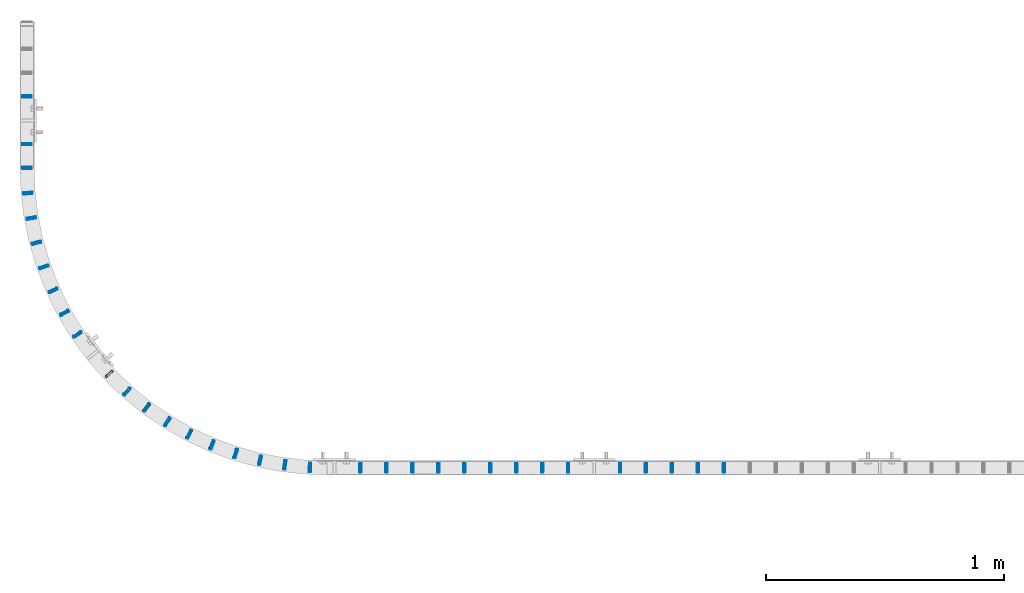
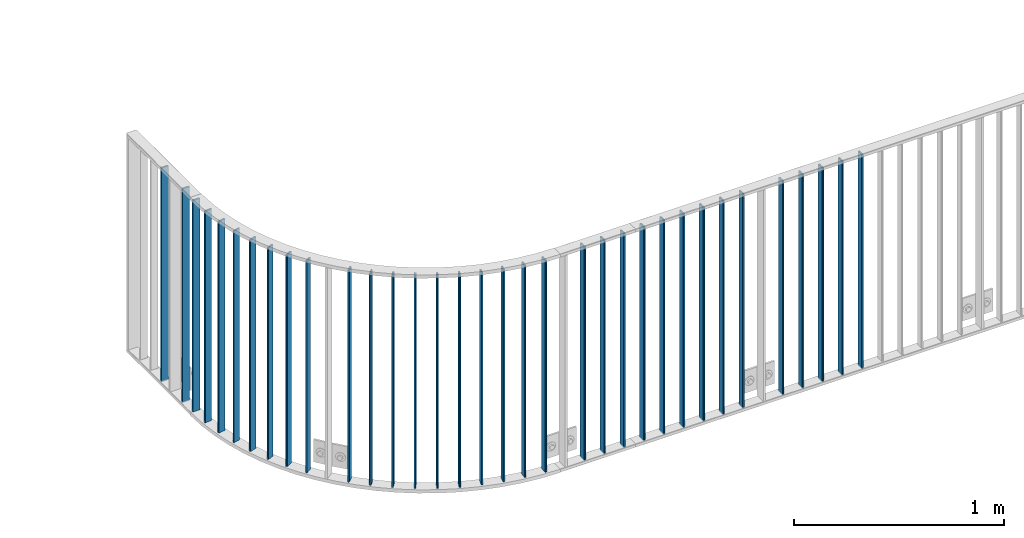
# One storey, part 1 of 156: 34 beams, 2 elements without a shape of their own.
"""IFC2X3 building model written with IfcOpenShell, lengths in millimetres."""

from ifc_helpers import new_model, si_unit, frame, origin_with_axes, origin_2d_with_axis, place, context, subcontext, project, spatial, hollow_rectangle, extrude, clip, halfspace, material, type_object, element, aggregate, save


model = new_model("IFC2X3")

# Units and contexts
model_context = context("Model", 3, precision=1e-05, world=origin_with_axes())
body_context = subcontext(model_context, "Body", "Model", "MODEL_VIEW")
ifc_project = project(units=[si_unit("LENGTHUNIT", "METRE", prefix="MILLI"), si_unit("AREAUNIT", "SQUARE_METRE"), si_unit("VOLUMEUNIT", "CUBIC_METRE"), si_unit("MASSUNIT", "GRAM", prefix="KILO"), si_unit("TIMEUNIT", "SECOND"), si_unit("PLANEANGLEUNIT", "RADIAN"), si_unit("SOLIDANGLEUNIT", "STERADIAN"), si_unit("THERMODYNAMICTEMPERATUREUNIT", "DEGREE_CELSIUS"), si_unit("LUMINOUSINTENSITYUNIT", "LUMEN")], contexts=[model_context])

# Site, building, storey
site_placement = place(None, origin_with_axes())
site = spatial("IfcSite", under=ifc_project, at=site_placement, CompositionType="ELEMENT")
building_placement = place(site_placement, origin_with_axes())
building = spatial("IfcBuilding", under=site, at=building_placement, Name="Undefined", CompositionType="ELEMENT")
storey_placement = place(building_placement, origin_with_axes())
storey = spatial("IfcBuildingStorey", under=building, at=storey_placement, Name="Undefined", CompositionType="ELEMENT", Elevation=0.0)

# Assembly, beams
assembly_1_placement = place(storey_placement, origin_with_axes())
assembly_1 = element("IfcElementAssembly", 1, at=assembly_1_placement, inside=storey, AssemblyPlace="NOTDEFINED", PredefinedType="RIGID_FRAME")
ifc_material = material(Name="STEEL/S235JR")
beam_type = type_object("IfcBeamType", Name="K40/10/1.5", PredefinedType="NOTDEFINED")
beam_1_placement = place(assembly_1_placement, frame((9618.18999999898, 10879.9998093347, 3980.00000000003), z_axis=(0.0, 1.0, 0.0), x_axis=(0.0, 0.0, -1.0)))
beam_1 = element("IfcBeam", 2, at=beam_1_placement, type_object=beam_type, material=ifc_material, ObjectType="K40/10/1.5", context=body_context, shape_type="Clipping", body=[
    clip(clip(extrude(hollow_rectangle(XDim=10.0, YDim=40.0, WallThickness=1.5, InnerFilletRadius=1.5, OuterFilletRadius=3.0, at=origin_2d_with_axis()), frame((1237.00000000003, 0.0, 0.0), z_axis=(-1.0, 0.0, 0.0), x_axis=(0.0, -1.0, 0.0)), (0.0, 0.0, 1.0), 1244.0), halfspace(frame((1237.00000000003, -56.3749450640607, -3.21677039569113), z_axis=(1.0, 0.0, 0.0), x_axis=(0.0, -0.0578016017852366, -0.998328089773628)), False)), halfspace(frame((-6.99999999997408, 56.3749450528248, -3.21677038838243), z_axis=(-1.0, 0.0, 0.0), x_axis=(0.0, 0.0578016019523036, -0.998328089763955)), False)),
])
beam_2_placement = place(assembly_1_placement, frame((8216.99947364132, 12239.9989152168, 3980.00000000003), z_axis=(1.0, 0.0, 0.0), x_axis=(0.0, 0.0, -1.0)))
beam_2 = element("IfcBeam", 3, at=beam_2_placement, type_object=beam_type, material=ifc_material, ObjectType="K40/10/1.5", context=body_context, shape_type="Clipping", body=[
    clip(clip(extrude(hollow_rectangle(XDim=10.0, YDim=40.0, WallThickness=1.5, InnerFilletRadius=1.5, OuterFilletRadius=3.0, at=origin_2d_with_axis()), frame((1237.00000000003, 0.0, 0.0), z_axis=(-1.0, 0.0, 0.0), x_axis=(0.0, -1.0, 0.0)), (0.0, 0.0, 1.0), 1244.0), halfspace(frame((1237.00000000003, -56.3749450640607, -3.21677039569113), z_axis=(1.0, 0.0, 0.0), x_axis=(0.0, -0.0578016017852366, -0.998328089773628)), False)), halfspace(frame((-6.99999999997408, 56.3749450528248, -3.21677038838243), z_axis=(-1.0, 0.0, 0.0), x_axis=(0.0, 0.0578016019523036, -0.998328089763955)), False)),
])
beam_3_placement = place(assembly_1_placement, frame((8216.99947364132, 12439.9989152168, 3980.00000000003), z_axis=(1.0, 0.0, 0.0), x_axis=(0.0, 0.0, -1.0)))
beam_3 = element("IfcBeam", 4, at=beam_3_placement, type_object=beam_type, material=ifc_material, ObjectType="K40/10/1.5", context=body_context, shape_type="Clipping", body=[
    clip(clip(extrude(hollow_rectangle(XDim=10.0, YDim=40.0, WallThickness=1.5, InnerFilletRadius=1.5, OuterFilletRadius=3.0, at=origin_2d_with_axis()), frame((1237.00000000003, 0.0, 0.0), z_axis=(-1.0, 0.0, 0.0), x_axis=(0.0, -1.0, 0.0)), (0.0, 0.0, 1.0), 1244.0), halfspace(frame((1237.00000000003, -56.3749450640607, -3.21677039569113), z_axis=(1.0, 0.0, 0.0), x_axis=(0.0, -0.0578016017852366, -0.998328089773628)), False)), halfspace(frame((-6.99999999997408, 56.3749450528248, -3.21677038838243), z_axis=(-1.0, 0.0, 0.0), x_axis=(0.0, 0.0578016019523036, -0.998328089763955)), False)),
])
beam_4_placement = place(assembly_1_placement, frame((9405.79598262836, 10882.0035335241, 3980.00000000003), z_axis=(0.0565185340076896, 0.998401550135827, 0.0), x_axis=(0.0, 0.0, -1.0)))
beam_4 = element("IfcBeam", 5, at=beam_4_placement, type_object=beam_type, material=ifc_material, ObjectType="K40/10/1.5", context=body_context, shape_type="SweptSolid", body=[
    extrude(hollow_rectangle(XDim=10.0, YDim=40.0, WallThickness=1.5, InnerFilletRadius=1.5, OuterFilletRadius=3.0, at=origin_2d_with_axis()), frame((1230.0, 0.0, 0.0), z_axis=(-1.0, 0.0, 0.0), x_axis=(0.0, -1.0, 0.0)), (0.0, 0.0, 1.0), 1230.0),
])
beam_5_placement = place(assembly_1_placement, frame((9300.34381627942, 10892.4361317088, 3980.00000000003), z_axis=(0.1402100310039, 0.990121784027543, 0.0), x_axis=(0.0, 0.0, -1.0)))
beam_5 = element("IfcBeam", 6, at=beam_5_placement, type_object=beam_type, material=ifc_material, ObjectType="K40/10/1.5", context=body_context, shape_type="SweptSolid", body=[
    extrude(hollow_rectangle(XDim=10.0, YDim=40.0, WallThickness=1.5, InnerFilletRadius=1.5, OuterFilletRadius=3.0, at=origin_2d_with_axis()), frame((1230.0, 0.0, 0.0), z_axis=(-1.0, 0.0, 0.0), x_axis=(0.0, -1.0, 0.0)), (0.0, 0.0, 1.0), 1230.0),
])
beam_6_placement = place(assembly_1_placement, frame((9196.14117823786, 10911.6925259129, 3980.00000000003), z_axis=(0.222909846934246, 0.974839063712442, 0.0), x_axis=(0.0, 0.0, -1.0)))
beam_6 = element("IfcBeam", 7, at=beam_6_placement, type_object=beam_type, material=ifc_material, ObjectType="K40/10/1.5", context=body_context, shape_type="SweptSolid", body=[
    extrude(hollow_rectangle(XDim=10.0, YDim=40.0, WallThickness=1.5, InnerFilletRadius=1.5, OuterFilletRadius=3.0, at=origin_2d_with_axis()), frame((1230.0, 0.0, 0.0), z_axis=(-1.0, 0.0, 0.0), x_axis=(0.0, -1.0, 0.0)), (0.0, 0.0, 1.0), 1230.0),
])
beam_7_placement = place(assembly_1_placement, frame((9093.92507511803, 10939.6365191058, 3980.00000000003), z_axis=(0.304033061066562, 0.952661481208565, 0.0), x_axis=(0.0, 0.0, -1.0)))
beam_7 = element("IfcBeam", 8, at=beam_7_placement, type_object=beam_type, material=ifc_material, ObjectType="K40/10/1.5", context=body_context, shape_type="SweptSolid", body=[
    extrude(hollow_rectangle(XDim=10.0, YDim=40.0, WallThickness=1.5, InnerFilletRadius=1.5, OuterFilletRadius=3.0, at=origin_2d_with_axis()), frame((1230.0, 0.0, 0.0), z_axis=(-1.0, 0.0, 0.0), x_axis=(0.0, -1.0, 0.0)), (0.0, 0.0, 1.0), 1230.0),
])
beam_8_placement = place(assembly_1_placement, frame((8994.41846312824, 10976.0704684235, 3980.00000000003), z_axis=(0.383005903803094, 0.923745894525099, 0.0), x_axis=(0.0, 0.0, -1.0)))
beam_8 = element("IfcBeam", 9, at=beam_8_placement, type_object=beam_type, material=ifc_material, ObjectType="K40/10/1.5", context=body_context, shape_type="SweptSolid", body=[
    extrude(hollow_rectangle(XDim=10.0, YDim=40.0, WallThickness=1.5, InnerFilletRadius=1.5, OuterFilletRadius=3.0, at=origin_2d_with_axis()), frame((1230.0, 0.0, 0.0), z_axis=(-1.0, 0.0, 0.0), x_axis=(0.0, -1.0, 0.0)), (0.0, 0.0, 1.0), 1230.0),
])
beam_9_placement = place(assembly_1_placement, frame((8898.32513473082, 11020.7366830613, 3980.00000000003), z_axis=(0.459269815036958, 0.888296818071481, 0.0), x_axis=(0.0, 0.0, -1.0)))
beam_9 = element("IfcBeam", 10, at=beam_9_placement, type_object=beam_type, material=ifc_material, ObjectType="K40/10/1.5", context=body_context, shape_type="SweptSolid", body=[
    extrude(hollow_rectangle(XDim=10.0, YDim=40.0, WallThickness=1.5, InnerFilletRadius=1.5, OuterFilletRadius=3.0, at=origin_2d_with_axis()), frame((1230.0, 0.0, 0.0), z_axis=(-1.0, 0.0, 0.0), x_axis=(0.0, -1.0, 0.0)), (0.0, 0.0, 1.0), 1230.0),
])
beam_10_placement = place(assembly_1_placement, frame((8806.32474084398, 11073.3192468752, 3980.00000000003), z_axis=(0.532285391863539, 0.846564977782969, 0.0), x_axis=(0.0, 0.0, -1.0)))
beam_10 = element("IfcBeam", 11, at=beam_10_placement, type_object=beam_type, material=ifc_material, ObjectType="K40/10/1.5", context=body_context, shape_type="SweptSolid", body=[
    extrude(hollow_rectangle(XDim=10.0, YDim=40.0, WallThickness=1.5, InnerFilletRadius=1.5, OuterFilletRadius=3.0, at=origin_2d_with_axis()), frame((1230.0, 0.0, 0.0), z_axis=(-1.0, 0.0, 0.0), x_axis=(0.0, -1.0, 0.0)), (0.0, 0.0, 1.0), 1230.0),
])
beam_11_placement = place(assembly_1_placement, frame((8719.06798379248, 11133.4462527995, 3980.00000000003), z_axis=(0.601536210260794, 0.798845534346335, 0.0), x_axis=(0.0, 0.0, -1.0)))
beam_11 = element("IfcBeam", 12, at=beam_11_placement, type_object=beam_type, material=ifc_material, ObjectType="K40/10/1.5", context=body_context, shape_type="SweptSolid", body=[
    extrude(hollow_rectangle(XDim=10.0, YDim=40.0, WallThickness=1.5, InnerFilletRadius=1.5, OuterFilletRadius=3.0, at=origin_2d_with_axis()), frame((1230.0, 0.0, 0.0), z_axis=(-1.0, 0.0, 0.0), x_axis=(0.0, -1.0, 0.0)), (0.0, 0.0, 1.0), 1230.0),
])
beam_12_placement = place(assembly_1_placement, frame((8637.17201500647, 11200.6924332796, 3980.00000000003), z_axis=(0.666532469953243, 0.745475999947704, 0.0), x_axis=(0.0, 0.0, -1.0)))
beam_12 = element("IfcBeam", 13, at=beam_12_placement, type_object=beam_type, material=ifc_material, ObjectType="K40/10/1.5", context=body_context, shape_type="SweptSolid", body=[
    extrude(hollow_rectangle(XDim=10.0, YDim=40.0, WallThickness=1.5, InnerFilletRadius=1.5, OuterFilletRadius=3.0, at=origin_2d_with_axis()), frame((1230.0, 0.0, 0.0), z_axis=(-1.0, 0.0, 0.0), x_axis=(0.0, -1.0, 0.0)), (0.0, 0.0, 1.0), 1230.0),
])
beam_13_placement = place(assembly_1_placement, frame((8561.21607001991, 11274.5821681131, 3980.00000000003), z_axis=(0.726814465029779, 0.686833847028142, 0.0), x_axis=(0.0, 0.0, -1.0)))
beam_13 = element("IfcBeam", 14, at=beam_13_placement, type_object=beam_type, material=ifc_material, ObjectType="K40/10/1.5", context=body_context, shape_type="SweptSolid", body=[
    extrude(hollow_rectangle(XDim=10.0, YDim=40.0, WallThickness=1.5, InnerFilletRadius=1.5, OuterFilletRadius=3.0, at=origin_2d_with_axis()), frame((1230.0, 0.0, 0.0), z_axis=(-1.0, 0.0, 0.0), x_axis=(0.0, -1.0, 0.0)), (0.0, 0.0, 1.0), 1230.0),
])
beam_14_placement = place(assembly_1_placement, frame((8429.22733027256, 11440.1585729931, 3980.00000000003), z_axis=(0.831566564833267, 0.555425105888634, 0.0), x_axis=(0.0, 0.0, -1.0)))
beam_14 = element("IfcBeam", 15, at=beam_14_placement, type_object=beam_type, material=ifc_material, ObjectType="K40/10/1.5", context=body_context, shape_type="SweptSolid", body=[
    extrude(hollow_rectangle(XDim=10.0, YDim=40.0, WallThickness=1.5, InnerFilletRadius=1.5, OuterFilletRadius=3.0, at=origin_2d_with_axis()), frame((1230.0, 0.0, 0.0), z_axis=(-1.0, 0.0, 0.0), x_axis=(0.0, -1.0, 0.0)), (0.0, 0.0, 1.0), 1230.0),
])
beam_15_placement = place(assembly_1_placement, frame((8374.12806825185, 11530.6741507538, 3980.00000000003), z_axis=(0.875295776043121, 0.483587949023826, 0.0), x_axis=(0.0, 0.0, -1.0)))
beam_15 = element("IfcBeam", 16, at=beam_15_placement, type_object=beam_type, material=ifc_material, ObjectType="K40/10/1.5", context=body_context, shape_type="SweptSolid", body=[
    extrude(hollow_rectangle(XDim=10.0, YDim=40.0, WallThickness=1.5, InnerFilletRadius=1.5, OuterFilletRadius=3.0, at=origin_2d_with_axis()), frame((1230.0, 0.0, 0.0), z_axis=(-1.0, 0.0, 0.0), x_axis=(0.0, -1.0, 0.0)), (0.0, 0.0, 1.0), 1230.0),
])
beam_16_placement = place(assembly_1_placement, frame((8326.82929280072, 11625.4993812222, 3980.00000000003), z_axis=(0.912834177336344, 0.408330460150453, 0.0), x_axis=(0.0, 0.0, -1.0)))
beam_16 = element("IfcBeam", 17, at=beam_16_placement, type_object=beam_type, material=ifc_material, ObjectType="K40/10/1.5", context=body_context, shape_type="SweptSolid", body=[
    extrude(hollow_rectangle(XDim=10.0, YDim=40.0, WallThickness=1.5, InnerFilletRadius=1.5, OuterFilletRadius=3.0, at=origin_2d_with_axis()), frame((1230.0, 0.0, 0.0), z_axis=(-1.0, 0.0, 0.0), x_axis=(0.0, -1.0, 0.0)), (0.0, 0.0, 1.0), 1230.0),
])
beam_17_placement = place(assembly_1_placement, frame((8287.66553969498, 11723.96358251, 3980.00000000003), z_axis=(0.943916265298072, 0.330184924104266, 0.0), x_axis=(0.0, 0.0, -1.0)))
beam_17 = element("IfcBeam", 18, at=beam_17_placement, type_object=beam_type, material=ifc_material, ObjectType="K40/10/1.5", context=body_context, shape_type="SweptSolid", body=[
    extrude(hollow_rectangle(XDim=10.0, YDim=40.0, WallThickness=1.5, InnerFilletRadius=1.5, OuterFilletRadius=3.0, at=origin_2d_with_axis()), frame((1230.0, 0.0, 0.0), z_axis=(-1.0, 0.0, 0.0), x_axis=(0.0, -1.0, 0.0)), (0.0, 0.0, 1.0), 1230.0),
])
beam_18_placement = place(assembly_1_placement, frame((8256.91380715295, 11825.3703349392, 3980.00000000003), z_axis=(0.968322202559526, 0.249704048886413, 0.0), x_axis=(0.0, 0.0, -1.0)))
beam_18 = element("IfcBeam", 19, at=beam_18_placement, type_object=beam_type, material=ifc_material, ObjectType="K40/10/1.5", context=body_context, shape_type="SweptSolid", body=[
    extrude(hollow_rectangle(XDim=10.0, YDim=40.0, WallThickness=1.5, InnerFilletRadius=1.5, OuterFilletRadius=3.0, at=origin_2d_with_axis()), frame((1230.0, 0.0, 0.0), z_axis=(-1.0, 0.0, 0.0), x_axis=(0.0, -1.0, 0.0)), (0.0, 0.0, 1.0), 1230.0),
])
beam_19_placement = place(assembly_1_placement, frame((8234.79159667663, 11929.002406694, 3980.00000000003), z_axis=(0.985879370261083, 0.167457061044346, 0.0), x_axis=(0.0, 0.0, -1.0)))
beam_19 = element("IfcBeam", 20, at=beam_19_placement, type_object=beam_type, material=ifc_material, ObjectType="K40/10/1.5", context=body_context, shape_type="SweptSolid", body=[
    extrude(hollow_rectangle(XDim=10.0, YDim=40.0, WallThickness=1.5, InnerFilletRadius=1.5, OuterFilletRadius=3.0, at=origin_2d_with_axis()), frame((1230.0, 0.0, 0.0), z_axis=(-1.0, 0.0, 0.0), x_axis=(0.0, -1.0, 0.0)), (0.0, 0.0, 1.0), 1230.0),
])
beam_20_placement = place(assembly_1_placement, frame((8221.4553747025, 12034.1268266735, 3980.00000000003), z_axis=(0.996463589447301, 0.0840256800377192, 0.0), x_axis=(0.0, 0.0, -1.0)))
beam_20 = element("IfcBeam", 21, at=beam_20_placement, type_object=beam_type, material=ifc_material, ObjectType="K40/10/1.5", context=body_context, shape_type="SweptSolid", body=[
    extrude(hollow_rectangle(XDim=10.0, YDim=40.0, WallThickness=1.5, InnerFilletRadius=1.5, OuterFilletRadius=3.0, at=origin_2d_with_axis()), frame((1230.0, 0.0, 0.0), z_axis=(-1.0, 0.0, 0.0), x_axis=(0.0, -1.0, 0.0)), (0.0, 0.0, 1.0), 1230.0),
])
beam_21_placement = place(assembly_1_placement, frame((8216.99946594238, 12140.0000686646, 3980.00000000003), z_axis=(1.0, 0.0, 0.0), x_axis=(0.0, 0.0, -1.0)))
beam_21 = element("IfcBeam", 22, at=beam_21_placement, type_object=beam_type, material=ifc_material, ObjectType="K40/10/1.5", context=body_context, shape_type="SweptSolid", body=[
    extrude(hollow_rectangle(XDim=10.0, YDim=40.0, WallThickness=1.5, InnerFilletRadius=1.5, OuterFilletRadius=3.0, at=origin_2d_with_axis()), frame((1230.0, 0.0, 0.0), z_axis=(-1.0, 0.0, 0.0), x_axis=(0.0, -1.0, 0.0)), (0.0, 0.0, 1.0), 1230.0),
])

assembly_2_placement = place(storey_placement, origin_with_axes())
assembly_2 = element("IfcElementAssembly", 23, at=assembly_2_placement, inside=storey, AssemblyPlace="NOTDEFINED", PredefinedType="RIGID_FRAME")
beam_22_placement = place(assembly_2_placement, frame((10490.909999999, 10879.9998093347, 3980.00000000003), z_axis=(0.0, 1.0, 0.0), x_axis=(0.0, 0.0, -1.0)))
beam_22 = element("IfcBeam", 24, at=beam_22_placement, type_object=beam_type, material=ifc_material, ObjectType="K40/10/1.5", context=body_context, shape_type="Clipping", body=[
    clip(clip(extrude(hollow_rectangle(XDim=10.0, YDim=40.0, WallThickness=1.5, InnerFilletRadius=1.5, OuterFilletRadius=3.0, at=origin_2d_with_axis()), frame((1237.00000000003, 0.0, 0.0), z_axis=(-1.0, 0.0, 0.0), x_axis=(0.0, -1.0, 0.0)), (0.0, 0.0, 1.0), 1244.0), halfspace(frame((1237.00000000003, 1.80362172154128, 45.2653685592795), z_axis=(1.0, 0.0, 0.0), x_axis=(0.0, -0.737586551668085, -0.675252603696115)), False)), halfspace(frame((-6.99999999997453, -0.5315859633738, 44.2053387614833), z_axis=(-1.0, 0.0, 0.0), x_axis=(0.0, 0.722377441111346, -0.691498975106561)), False)),
])
beam_23_placement = place(assembly_2_placement, frame((10381.819999999, 10879.9998093347, 3980.00000000003), z_axis=(0.0, 1.0, 0.0), x_axis=(0.0, 0.0, -1.0)))
beam_23 = element("IfcBeam", 25, at=beam_23_placement, type_object=beam_type, material=ifc_material, ObjectType="K40/10/1.5", context=body_context, shape_type="Clipping", body=[
    clip(clip(extrude(hollow_rectangle(XDim=10.0, YDim=40.0, WallThickness=1.5, InnerFilletRadius=1.5, OuterFilletRadius=3.0, at=origin_2d_with_axis()), frame((1237.00000000003, 0.0, 0.0), z_axis=(-1.0, 0.0, 0.0), x_axis=(0.0, -1.0, 0.0)), (0.0, 0.0, 1.0), 1244.0), halfspace(frame((1237.00000000003, 1.80362172154128, 45.2653685592795), z_axis=(1.0, 0.0, 0.0), x_axis=(0.0, -0.737586551668085, -0.675252603696115)), False)), halfspace(frame((-6.99999999997453, -0.5315859633738, 44.2053387614833), z_axis=(-1.0, 0.0, 0.0), x_axis=(0.0, 0.722377441111346, -0.691498975106561)), False)),
])
beam_24_placement = place(assembly_2_placement, frame((10272.729999999, 10879.9998093347, 3980.00000000003), z_axis=(0.0, 1.0, 0.0), x_axis=(0.0, 0.0, -1.0)))
beam_24 = element("IfcBeam", 26, at=beam_24_placement, type_object=beam_type, material=ifc_material, ObjectType="K40/10/1.5", context=body_context, shape_type="Clipping", body=[
    clip(clip(extrude(hollow_rectangle(XDim=10.0, YDim=40.0, WallThickness=1.5, InnerFilletRadius=1.5, OuterFilletRadius=3.0, at=origin_2d_with_axis()), frame((1237.00000000003, 0.0, 0.0), z_axis=(-1.0, 0.0, 0.0), x_axis=(0.0, -1.0, 0.0)), (0.0, 0.0, 1.0), 1244.0), halfspace(frame((1237.00000000003, 1.80362172154128, 45.2653685592795), z_axis=(1.0, 0.0, 0.0), x_axis=(0.0, -0.737586551668085, -0.675252603696115)), False)), halfspace(frame((-6.99999999997453, -0.5315859633738, 44.2053387614833), z_axis=(-1.0, 0.0, 0.0), x_axis=(0.0, 0.722377441111346, -0.691498975106561)), False)),
])
beam_25_placement = place(assembly_2_placement, frame((10163.639999999, 10879.9998093347, 3980.00000000003), z_axis=(0.0, 1.0, 0.0), x_axis=(0.0, 0.0, -1.0)))
beam_25 = element("IfcBeam", 27, at=beam_25_placement, type_object=beam_type, material=ifc_material, ObjectType="K40/10/1.5", context=body_context, shape_type="Clipping", body=[
    clip(clip(extrude(hollow_rectangle(XDim=10.0, YDim=40.0, WallThickness=1.5, InnerFilletRadius=1.5, OuterFilletRadius=3.0, at=origin_2d_with_axis()), frame((1237.00000000003, 0.0, 0.0), z_axis=(-1.0, 0.0, 0.0), x_axis=(0.0, -1.0, 0.0)), (0.0, 0.0, 1.0), 1244.0), halfspace(frame((1237.00000000003, 1.80362172154128, 45.2653685592795), z_axis=(1.0, 0.0, 0.0), x_axis=(0.0, -0.737586551668085, -0.675252603696115)), False)), halfspace(frame((-6.99999999997453, -0.5315859633738, 44.2053387614833), z_axis=(-1.0, 0.0, 0.0), x_axis=(0.0, 0.722377441111346, -0.691498975106561)), False)),
])
beam_26_placement = place(assembly_2_placement, frame((10054.549999999, 10879.9998093347, 3980.00000000003), z_axis=(0.0, 1.0, 0.0), x_axis=(0.0, 0.0, -1.0)))
beam_26 = element("IfcBeam", 28, at=beam_26_placement, type_object=beam_type, material=ifc_material, ObjectType="K40/10/1.5", context=body_context, shape_type="Clipping", body=[
    clip(clip(extrude(hollow_rectangle(XDim=10.0, YDim=40.0, WallThickness=1.5, InnerFilletRadius=1.5, OuterFilletRadius=3.0, at=origin_2d_with_axis()), frame((1237.00000000003, 0.0, 0.0), z_axis=(-1.0, 0.0, 0.0), x_axis=(0.0, -1.0, 0.0)), (0.0, 0.0, 1.0), 1244.0), halfspace(frame((1237.00000000003, 1.80362172154128, 45.2653685592795), z_axis=(1.0, 0.0, 0.0), x_axis=(0.0, -0.737586551668085, -0.675252603696115)), False)), halfspace(frame((-6.99999999997453, -0.5315859633738, 44.2053387614833), z_axis=(-1.0, 0.0, 0.0), x_axis=(0.0, 0.722377441111346, -0.691498975106561)), False)),
])
beam_27_placement = place(assembly_2_placement, frame((9945.45999999898, 10879.9998093347, 3980.00000000003), z_axis=(0.0, 1.0, 0.0), x_axis=(0.0, 0.0, -1.0)))
beam_27 = element("IfcBeam", 29, at=beam_27_placement, type_object=beam_type, material=ifc_material, ObjectType="K40/10/1.5", context=body_context, shape_type="Clipping", body=[
    clip(clip(extrude(hollow_rectangle(XDim=10.0, YDim=40.0, WallThickness=1.5, InnerFilletRadius=1.5, OuterFilletRadius=3.0, at=origin_2d_with_axis()), frame((1237.00000000003, 0.0, 0.0), z_axis=(-1.0, 0.0, 0.0), x_axis=(0.0, -1.0, 0.0)), (0.0, 0.0, 1.0), 1244.0), halfspace(frame((1237.00000000003, 1.80362172154128, 45.2653685592795), z_axis=(1.0, 0.0, 0.0), x_axis=(0.0, -0.737586551668085, -0.675252603696115)), False)), halfspace(frame((-6.99999999997453, -0.5315859633738, 44.2053387614833), z_axis=(-1.0, 0.0, 0.0), x_axis=(0.0, 0.722377441111346, -0.691498975106561)), False)),
])

# Beam
beam_28_placement = place(assembly_1_placement, frame((9836.36999999898, 10879.9998093347, 3980.00000000003), z_axis=(0.0, 1.0, 0.0), x_axis=(0.0, 0.0, -1.0)))
beam_28 = element("IfcBeam", 30, at=beam_28_placement, type_object=beam_type, material=ifc_material, ObjectType="K40/10/1.5", context=body_context, shape_type="Clipping", body=[
    clip(clip(extrude(hollow_rectangle(XDim=10.0, YDim=40.0, WallThickness=1.5, InnerFilletRadius=1.5, OuterFilletRadius=3.0, at=origin_2d_with_axis()), frame((1237.00000000003, 0.0, 0.0), z_axis=(-1.0, 0.0, 0.0), x_axis=(0.0, -1.0, 0.0)), (0.0, 0.0, 1.0), 1244.0), halfspace(frame((1237.00000000003, -56.3749450640607, -3.21677039569113), z_axis=(1.0, 0.0, 0.0), x_axis=(0.0, -0.0578016017852366, -0.998328089773628)), False)), halfspace(frame((-6.99999999997408, 56.3749450528248, -3.21677038838243), z_axis=(-1.0, 0.0, 0.0), x_axis=(0.0, 0.0578016019523036, -0.998328089763955)), False)),
])

beam_29_placement = place(assembly_1_placement, frame((9727.27999999898, 10879.9998093347, 3980.00000000003), z_axis=(0.0, 1.0, 0.0), x_axis=(0.0, 0.0, -1.0)))
beam_29 = element("IfcBeam", 31, at=beam_29_placement, type_object=beam_type, material=ifc_material, ObjectType="K40/10/1.5", context=body_context, shape_type="Clipping", body=[
    clip(clip(extrude(hollow_rectangle(XDim=10.0, YDim=40.0, WallThickness=1.5, InnerFilletRadius=1.5, OuterFilletRadius=3.0, at=origin_2d_with_axis()), frame((1237.00000000003, 0.0, 0.0), z_axis=(-1.0, 0.0, 0.0), x_axis=(0.0, -1.0, 0.0)), (0.0, 0.0, 1.0), 1244.0), halfspace(frame((1237.00000000003, -56.3749450640607, -3.21677039569113), z_axis=(1.0, 0.0, 0.0), x_axis=(0.0, -0.0578016017852366, -0.998328089773628)), False)), halfspace(frame((-6.99999999997408, 56.3749450528248, -3.21677038838243), z_axis=(-1.0, 0.0, 0.0), x_axis=(0.0, 0.0578016019523036, -0.998328089763955)), False)),
])

aggregate(assembly_1, [beam_1, beam_2, beam_3, beam_4, beam_5, beam_6, beam_7, beam_8, beam_9, beam_10, beam_11, beam_12, beam_13, beam_14, beam_15, beam_16, beam_17, beam_18, beam_19, beam_20, beam_21, beam_28, beam_29])

beam_30_placement = place(assembly_2_placement, frame((11145.449999999, 10879.9998088346, 3980.00000000003), z_axis=(0.0, 1.0, 0.0), x_axis=(0.0, 0.0, -1.0)))
beam_30 = element("IfcBeam", 32, at=beam_30_placement, type_object=beam_type, material=ifc_material, ObjectType="K40/10/1.5", context=body_context, shape_type="Clipping", body=[
    clip(clip(extrude(hollow_rectangle(XDim=10.0, YDim=40.0, WallThickness=1.5, InnerFilletRadius=1.5, OuterFilletRadius=3.0, at=origin_2d_with_axis()), frame((1237.00000000003, 0.0, 0.0), z_axis=(-1.0, 0.0, 0.0), x_axis=(0.0, -1.0, 0.0)), (0.0, 0.0, 1.0), 1244.0), halfspace(frame((1237.00000000003, 0.531585963377438, 44.2053387614833), z_axis=(1.0, 0.0, 0.0), x_axis=(0.0, -0.72237744111132, -0.691498975106588)), False)), halfspace(frame((-6.99999999997453, 1.34995955444174, 42.6373841643144), z_axis=(-1.0, 0.0, 0.0), x_axis=(0.0, 0.699320698559008, -0.714808058549245)), False)),
])

beam_31_placement = place(assembly_2_placement, frame((11036.359999999, 10879.9998088346, 3980.00000000003), z_axis=(0.0, 1.0, 0.0), x_axis=(0.0, 0.0, -1.0)))
beam_31 = element("IfcBeam", 33, at=beam_31_placement, type_object=beam_type, material=ifc_material, ObjectType="K40/10/1.5", context=body_context, shape_type="Clipping", body=[
    clip(clip(extrude(hollow_rectangle(XDim=10.0, YDim=40.0, WallThickness=1.5, InnerFilletRadius=1.5, OuterFilletRadius=3.0, at=origin_2d_with_axis()), frame((1237.00000000003, 0.0, 0.0), z_axis=(-1.0, 0.0, 0.0), x_axis=(0.0, -1.0, 0.0)), (0.0, 0.0, 1.0), 1244.0), halfspace(frame((1237.00000000003, 0.531585963377438, 44.2053387614833), z_axis=(1.0, 0.0, 0.0), x_axis=(0.0, -0.72237744111132, -0.691498975106588)), False)), halfspace(frame((-6.99999999997453, 1.34995955444174, 42.6373841643144), z_axis=(-1.0, 0.0, 0.0), x_axis=(0.0, 0.699320698559008, -0.714808058549245)), False)),
])

beam_32_placement = place(assembly_2_placement, frame((10927.269999999, 10879.9998088346, 3980.00000000003), z_axis=(0.0, 1.0, 0.0), x_axis=(0.0, 0.0, -1.0)))
beam_32 = element("IfcBeam", 34, at=beam_32_placement, type_object=beam_type, material=ifc_material, ObjectType="K40/10/1.5", context=body_context, shape_type="Clipping", body=[
    clip(clip(extrude(hollow_rectangle(XDim=10.0, YDim=40.0, WallThickness=1.5, InnerFilletRadius=1.5, OuterFilletRadius=3.0, at=origin_2d_with_axis()), frame((1237.00000000003, 0.0, 0.0), z_axis=(-1.0, 0.0, 0.0), x_axis=(0.0, -1.0, 0.0)), (0.0, 0.0, 1.0), 1244.0), halfspace(frame((1237.00000000003, 0.531585963377438, 44.2053387614833), z_axis=(1.0, 0.0, 0.0), x_axis=(0.0, -0.72237744111132, -0.691498975106588)), False)), halfspace(frame((-6.99999999997453, 1.34995955444174, 42.6373841643144), z_axis=(-1.0, 0.0, 0.0), x_axis=(0.0, 0.699320698559008, -0.714808058549245)), False)),
])

beam_33_placement = place(assembly_2_placement, frame((10818.179999999, 10879.9998088346, 3980.00000000003), z_axis=(0.0, 1.0, 0.0), x_axis=(0.0, 0.0, -1.0)))
beam_33 = element("IfcBeam", 35, at=beam_33_placement, type_object=beam_type, material=ifc_material, ObjectType="K40/10/1.5", context=body_context, shape_type="Clipping", body=[
    clip(clip(extrude(hollow_rectangle(XDim=10.0, YDim=40.0, WallThickness=1.5, InnerFilletRadius=1.5, OuterFilletRadius=3.0, at=origin_2d_with_axis()), frame((1237.00000000003, 0.0, 0.0), z_axis=(-1.0, 0.0, 0.0), x_axis=(0.0, -1.0, 0.0)), (0.0, 0.0, 1.0), 1244.0), halfspace(frame((1237.00000000003, 0.531585963377438, 44.2053387614833), z_axis=(1.0, 0.0, 0.0), x_axis=(0.0, -0.72237744111132, -0.691498975106588)), False)), halfspace(frame((-6.99999999997453, 1.34995955444174, 42.6373841643144), z_axis=(-1.0, 0.0, 0.0), x_axis=(0.0, 0.699320698559008, -0.714808058549245)), False)),
])

beam_34_placement = place(assembly_2_placement, frame((10709.089999999, 10879.9998088346, 3980.00000000003), z_axis=(0.0, 1.0, 0.0), x_axis=(0.0, 0.0, -1.0)))
beam_34 = element("IfcBeam", 36, at=beam_34_placement, type_object=beam_type, material=ifc_material, ObjectType="K40/10/1.5", context=body_context, shape_type="Clipping", body=[
    clip(clip(extrude(hollow_rectangle(XDim=10.0, YDim=40.0, WallThickness=1.5, InnerFilletRadius=1.5, OuterFilletRadius=3.0, at=origin_2d_with_axis()), frame((1237.00000000003, 0.0, 0.0), z_axis=(-1.0, 0.0, 0.0), x_axis=(0.0, -1.0, 0.0)), (0.0, 0.0, 1.0), 1244.0), halfspace(frame((1237.00000000003, -1.3499595544381, 42.6373841643144), z_axis=(1.0, 0.0, 0.0), x_axis=(0.0, -0.69932069855901, -0.714808058549243)), False)), halfspace(frame((-6.99999999997453, 4.13306805682623, 40.3181270800669), z_axis=(-1.0, 0.0, 0.0), x_axis=(0.0, 0.664158250909421, -0.747592012898037)), False)),
])

aggregate(assembly_2, [beam_22, beam_23, beam_24, beam_25, beam_26, beam_27, beam_30, beam_31, beam_32, beam_33, beam_34])

save(model, "model.ifc")
